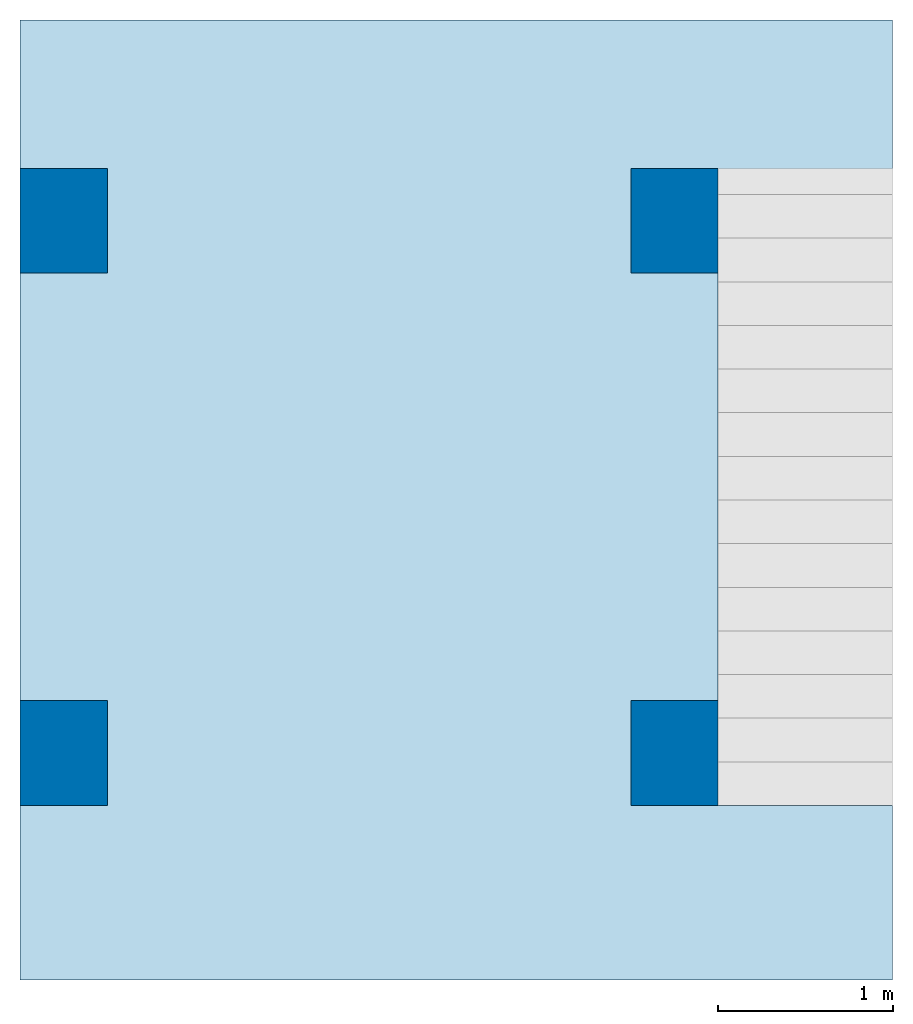
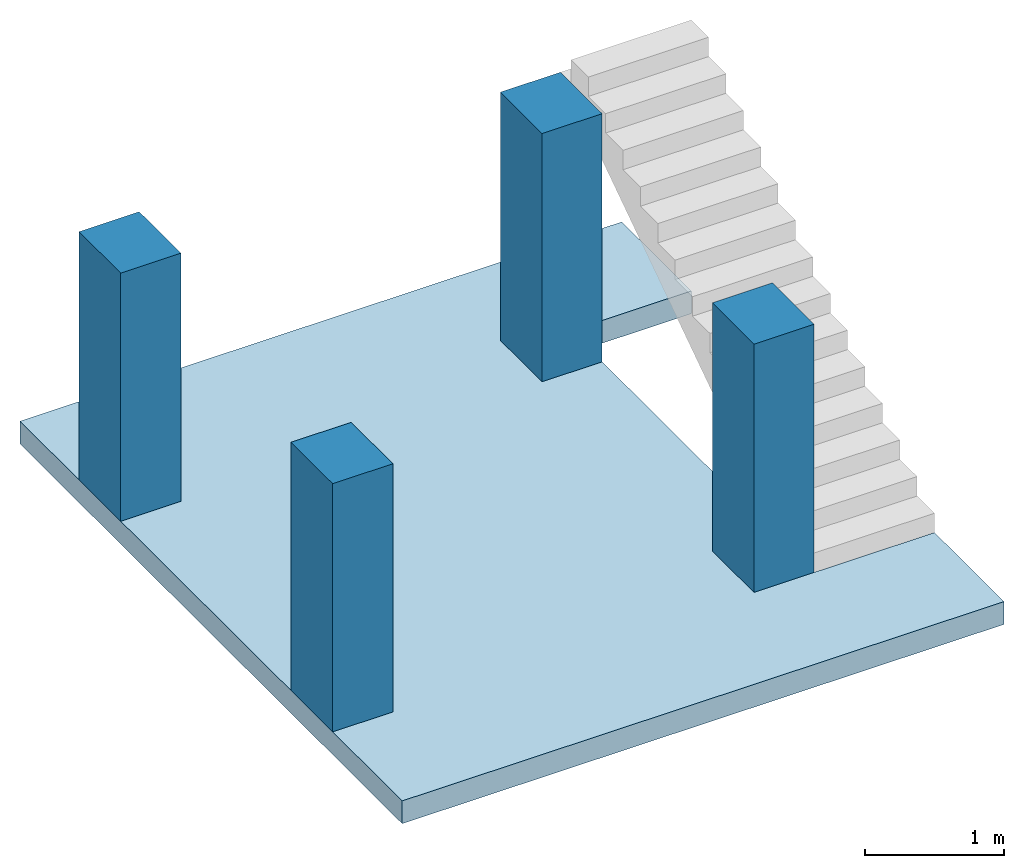
# One storey, part 1 of 2: 4 columns, 1 slab.
"""IFC4 building model written with IfcOpenShell, lengths in millimetres."""

from ifc_helpers import new_model, entity, si_unit, converted_unit, frame, origin_with_axes, origin_2d_with_axis, place, context, subcontext, project, spatial, line, indexed_curve, rectangle, outline, extrude, material, layer, layer_set, layer_usage, material_profile, profile_set, profile_usage, type_object, element, save


model = new_model("IFC4")

# Units and contexts
model_context = context("Model", 3, precision=1e-05, world=origin_with_axes())
plan_context = context("Plan", 2, precision=1e-05, world=origin_2d_with_axis())
body_context = subcontext(model_context, "Body", "Model", "MODEL_VIEW")
ifc_project = project(units=[si_unit("VOLUMEUNIT", "CUBIC_METRE", prefix="MILLI"), si_unit("LENGTHUNIT", "METRE", prefix="MILLI"), converted_unit("PLANEANGLEUNIT", "degree", entity("IfcReal", 0.0174532925199433), si_unit("PLANEANGLEUNIT", "RADIAN"), dimensions=[0, 0, 0, 0, 0, 0, 0]), si_unit("AREAUNIT", "SQUARE_METRE", prefix="MILLI")], contexts=[model_context, plan_context])

# Site, building, storey
site_placement = place(None, origin_with_axes())
site = spatial("IfcSite", under=ifc_project, at=site_placement)
building_placement = place(site_placement, origin_with_axes())
building = spatial("IfcBuilding", under=site, at=building_placement, Name="Building")
storey_placement = place(building_placement, frame((0.0, 0.0, 2380.00011444092), z_axis=(0.0, 0.0, 1.0), x_axis=(1.0, 0.0, 0.0)))
storey = spatial("IfcBuildingStorey", under=building, at=storey_placement, Name="1st Floor")

# Columns
ifc_material = material()
ifc_material_profile = material_profile(ifc_material, rectangle(XDim=500.0, YDim=600.0))
ifc_profile_set = profile_set([ifc_material_profile])
ifc_profile_usage_1 = profile_usage(ifc_profile_set, cardinal=5)
column_type = type_object("IfcColumnType", Name="C1", PredefinedType="NOTDEFINED", material=ifc_profile_set)
column_1_placement = place(storey_placement, frame((3750.0, 4350.47721862793, 0.0), z_axis=(0.0, 0.0, 1.0), x_axis=(1.0, 0.0, 0.0)))
element("IfcColumn", 1, at=column_1_placement, inside=storey, type_object=column_type, material=ifc_profile_usage_1, Name="Column", PredefinedType="NOTDEFINED", context=body_context, shape_type="SweptSolid", body=[
    extrude(rectangle(XDim=500.0, YDim=600.0), origin_with_axes(), (0.0, 0.0, 1.0), 2180.00031007537),
])
ifc_profile_usage_2 = profile_usage(ifc_profile_set, cardinal=5)
column_2_placement = place(storey_placement, frame((3750.0, 1300.00019073486, 0.0), z_axis=(0.0, 0.0, 1.0), x_axis=(1.0, 0.0, 0.0)))
element("IfcColumn", 2, at=column_2_placement, inside=storey, type_object=column_type, material=ifc_profile_usage_2, Name="Column", PredefinedType="NOTDEFINED", context=body_context, shape_type="SweptSolid", body=[
    extrude(rectangle(XDim=500.0, YDim=600.0), origin_with_axes(), (0.0, 0.0, 1.0), 2180.00031007537),
])
ifc_profile_usage_3 = profile_usage(ifc_profile_set, cardinal=5)
column_3_placement = place(storey_placement, frame((250.0, 4350.47721862793, 0.0), z_axis=(0.0, 0.0, 1.0), x_axis=(1.0, 0.0, 0.0)))
element("IfcColumn", 3, at=column_3_placement, inside=storey, type_object=column_type, material=ifc_profile_usage_3, Name="Column", PredefinedType="NOTDEFINED", context=body_context, shape_type="SweptSolid", body=[
    extrude(rectangle(XDim=500.0, YDim=600.0), origin_with_axes(), (0.0, 0.0, 1.0), 2180.00009134275),
])
ifc_profile_usage_4 = profile_usage(ifc_profile_set, cardinal=5)
column_4_placement = place(storey_placement, frame((250.0, 1300.00019073486, 0.0), z_axis=(0.0, 0.0, 1.0), x_axis=(1.0, 0.0, 0.0)))
element("IfcColumn", 4, at=column_4_placement, inside=storey, type_object=column_type, material=ifc_profile_usage_4, Name="Column", PredefinedType="NOTDEFINED", context=body_context, shape_type="SweptSolid", body=[
    extrude(rectangle(XDim=500.0, YDim=600.0), origin_with_axes(), (0.0, 0.0, 1.0), 2180.00009134275),
])

# Slab
ifc_layer = layer(ifc_material, 200.0)
ifc_layer_set = layer_set([ifc_layer])
ifc_layer_usage = layer_usage(ifc_layer_set, "AXIS3", "POSITIVE", 0.0)
slab_type = type_object("IfcSlabType", Name="FLR150", PredefinedType="NOTDEFINED", material=ifc_layer_set)
slab_placement = place(storey_placement, frame((0.0, 0.0, -200.000047683716), z_axis=(0.0, 0.0, 1.0), x_axis=(1.0, 0.0, 0.0)))
element("IfcSlab", 5, at=slab_placement, inside=storey, type_object=slab_type, material=ifc_layer_usage, Name="Slab", PredefinedType="NOTDEFINED", context=body_context, shape_type="SweptSolid", body=[
    extrude(outline(indexed_curve([(0.0, 0.0), (5000.0, 0.0), (5000.0, 5500.0), (0.0, 5500.0), (5000.0, 4500.0), (5000.0, 1000.0), (4000.0, 4500.0), (4000.0, 1000.0)], segments=[line(6, 2), line(2, 1), line(1, 4), line(4, 3), line(3, 5), line(5, 7), line(7, 8), line(8, 6)], self_intersect=False)), None, (0.0, 0.0, 1.0), 200.0),
])

save(model, "model.ifc")
